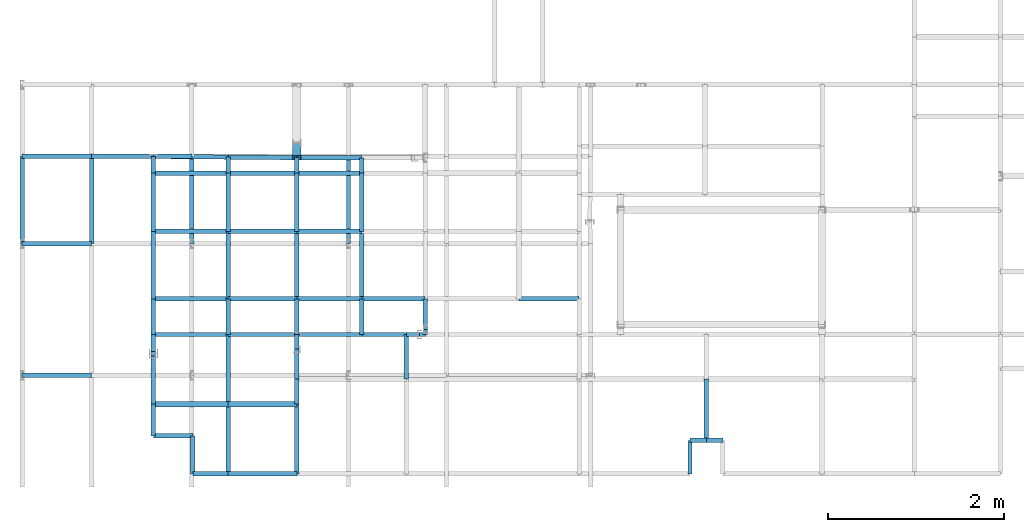
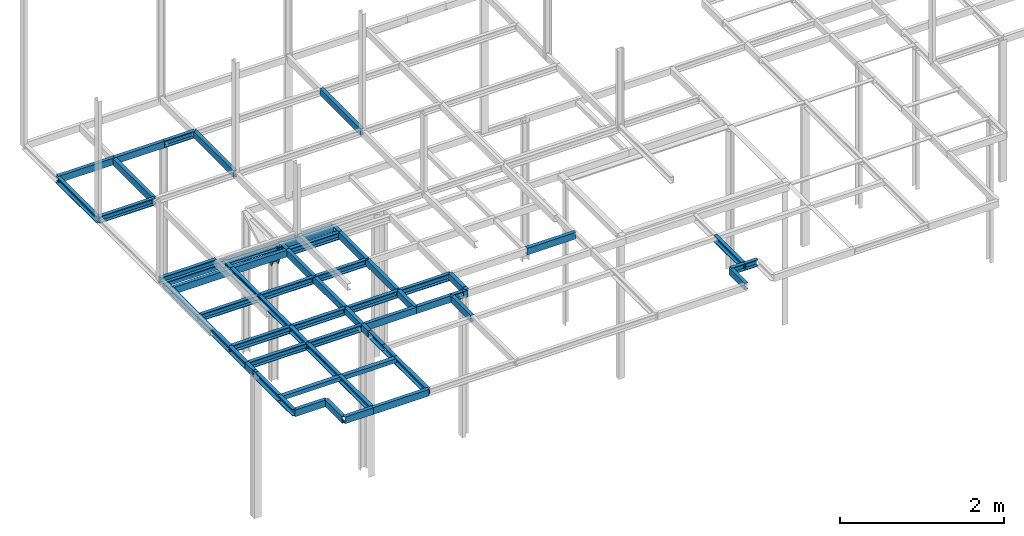
# Not in any storey, part 5 of 7: 68 beams, 1 member.
"""IFC2X3 model written with IfcOpenShell, lengths in centimetres."""

from ifc_helpers import new_model, si_unit, frame, frame_2d, origin_with_axes, origin_2d_with_axis, place, context, project, polyline, u_section, outline, extrude, material, element, save


model = new_model("IFC2X3")

# Units and contexts
model_context = context("Model", 3, precision=1e-05, world=origin_with_axes())
plan_context = context("Plan", 3, precision=1e-05, world=origin_with_axes())
ifc_project = project(units=[si_unit("LENGTHUNIT", "METRE", prefix="CENTI"), si_unit("AREAUNIT", "SQUARE_METRE", prefix="CENTI"), si_unit("VOLUMEUNIT", "CUBIC_METRE", prefix="CENTI"), si_unit("PLANEANGLEUNIT", "RADIAN"), si_unit("SOLIDANGLEUNIT", "STERADIAN"), si_unit("MASSUNIT", "GRAM"), si_unit("TIMEUNIT", "SECOND"), si_unit("THERMODYNAMICTEMPERATUREUNIT", "DEGREE_CELSIUS"), si_unit("LUMINOUSINTENSITYUNIT", "LUMEN")], contexts=[model_context, plan_context])

# Member
ifc_material = material()
member_placement = place(None, frame((-589.100036621094, 207.100006103516, 173.0), z_axis=(0.0, -0.377853352627, 0.925865456699), x_axis=(0.0, -0.925865471363, -0.377853363752)))
element("IfcMember", 1, at=member_placement, material=ifc_material, Name="UPN - de ala UPN 100", context=model_context, shape_type="SweptSolid", body=[
    extrude(u_section(Depth=10.0, FlangeWidth=5.0, WebThickness=0.6, FlangeThickness=0.85, FilletRadius=0.0, EdgeRadius=0.0, FlangeSlope=0.0, CentreOfGravityInX=0.0, at=origin_2d_with_axis()), origin_with_axes(), (0.0, 0.0, 1.0), 39.962609828766),
])

# Beams
beam_1_placement = place(None, frame((-667.0, 192.699996948242, 210.0), z_axis=(-0.999955816002, 0.009400321506, 0.0), x_axis=(0.009400321171, 0.999955832958, 0.0)))
element("IfcBeam", 2, at=beam_1_placement, material=ifc_material, Name="UPN - de ala UPN 100", context=model_context, shape_type="SweptSolid", body=[
    extrude(u_section(Depth=10.0, FlangeWidth=5.0, WebThickness=0.6, FlangeThickness=0.85, FilletRadius=0.0, EdgeRadius=0.0, FlangeSlope=0.0, CentreOfGravityInX=0.0, at=frame_2d((4.2114e-08, 0.0), x_axis=(1.0, 0.0))), origin_with_axes(), (0.0, 0.0, 1.0), 85.103796847111),
])
beam_2_placement = place(None, frame((-752.100036621094, 174.400009155273, 210.0), z_axis=(0.0, 1.0, 0.0), x_axis=(-1.0, 0.0, 0.0)))
element("IfcBeam", 3, at=beam_2_placement, material=ifc_material, Name="UPN - de ala UPN 100", context=model_context, shape_type="SweptSolid", body=[
    extrude(u_section(Depth=10.0, FlangeWidth=5.0, WebThickness=0.6, FlangeThickness=0.85, FilletRadius=0.0, EdgeRadius=0.0, FlangeSlope=0.0, CentreOfGravityInX=0.0, at=origin_2d_with_axis()), origin_with_axes(), (0.0, 0.0, 1.0), 19.099990844727),
])
beam_3_placement = place(None, frame((-589.100036621094, 192.0, 210.0), z_axis=(-0.999959629745, 0.008985481621, 0.0), x_axis=(-0.008985481225, -0.999959647655, 0.0)))
element("IfcBeam", 4, at=beam_3_placement, material=ifc_material, Name="UPN - de ala UPN 100", context=model_context, shape_type="SweptSolid", body=[
    extrude(u_section(Depth=10.0, FlangeWidth=5.0, WebThickness=0.6, FlangeThickness=0.85, FilletRadius=0.0, EdgeRadius=0.0, FlangeSlope=0.0, CentreOfGravityInX=0.0, at=frame_2d((-4.3358e-08, 0.0), x_axis=(1.0, 0.0))), origin_with_axes(), (0.0, 0.0, 1.0), 77.903108347244),
])
beam_4_placement = place(None, frame((-667.200012207031, 174.400009155273, 210.0), z_axis=(0.010928983338, 0.999940276878, 0.0), x_axis=(-0.999940276146, 0.0109289838, 0.0)))
element("IfcBeam", 5, at=beam_4_placement, material=ifc_material, Name="UPN - de ala UPN 100", context=model_context, shape_type="SweptSolid", body=[
    extrude(u_section(Depth=10.0, FlangeWidth=5.0, WebThickness=0.6, FlangeThickness=0.85, FilletRadius=0.0, EdgeRadius=0.0, FlangeSlope=0.0, CentreOfGravityInX=0.0, at=frame_2d((8.6e-09, 0.0), x_axis=(1.0, 0.0))), origin_with_axes(), (0.0, 0.0, 1.0), 18.301080790646),
])
beam_5_placement = place(None, frame((-515.200012207031, 191.900009155273, 210.0), z_axis=(-0.999999084621, 0.0013530544, 0.0), x_axis=(0.001353054424, 0.99999910593, 0.0)))
element("IfcBeam", 6, at=beam_5_placement, material=ifc_material, Name="UPN - de ala UPN 100", context=model_context, shape_type="SweptSolid", body=[
    extrude(u_section(Depth=10.0, FlangeWidth=5.0, WebThickness=0.6, FlangeThickness=0.85, FilletRadius=0.0, EdgeRadius=0.0, FlangeSlope=0.0, CentreOfGravityInX=0.0, at=frame_2d((3.74e-10, 0.0), x_axis=(1.0, 0.0))), origin_with_axes(), (0.0, 0.0, 1.0), 73.90009206062),
])
beam_6_placement = place(None, frame((-589.100036621094, 174.400009155273, 210.0), z_axis=(0.0, 1.0, 0.0), x_axis=(-1.0, 0.0, 0.0)))
element("IfcBeam", 7, at=beam_6_placement, material=ifc_material, Name="UPN - de ala UPN 100", context=model_context, shape_type="SweptSolid", body=[
    extrude(u_section(Depth=10.0, FlangeWidth=5.0, WebThickness=0.6, FlangeThickness=0.85, FilletRadius=0.0, EdgeRadius=0.0, FlangeSlope=0.0, CentreOfGravityInX=0.0, at=origin_2d_with_axis()), origin_with_axes(), (0.0, 0.0, 1.0), 17.599990844727),
])
beam_7_placement = place(None, frame((-515.200012207031, 174.400009155273, 210.0), z_axis=(0.0, 1.0, 0.0), x_axis=(-1.0, 0.0, 0.0)))
element("IfcBeam", 8, at=beam_7_placement, material=ifc_material, Name="UPN - de ala UPN 100", context=model_context, shape_type="SweptSolid", body=[
    extrude(u_section(Depth=10.0, FlangeWidth=5.0, WebThickness=0.6, FlangeThickness=0.85, FilletRadius=0.0, EdgeRadius=0.0, FlangeSlope=0.0, CentreOfGravityInX=0.0, at=origin_2d_with_axis()), origin_with_axes(), (0.0, 0.0, 1.0), 17.5),
])
beam_8_placement = place(None, frame((-667.200012207031, 174.400009155273, 210.0), z_axis=(-1.0, 0.0, 0.0), x_axis=(0.0, 1.0, 0.0)))
element("IfcBeam", 9, at=beam_8_placement, material=ifc_material, Name="UPN - de ala UPN 100", context=model_context, shape_type="SweptSolid", body=[
    extrude(u_section(Depth=10.0, FlangeWidth=5.0, WebThickness=0.6, FlangeThickness=0.85, FilletRadius=0.0, EdgeRadius=0.0, FlangeSlope=0.0, CentreOfGravityInX=0.0, at=origin_2d_with_axis()), origin_with_axes(), (0.0, 0.0, 1.0), 84.900024414062),
])
beam_9_placement = place(None, frame((-752.100036621094, 108.200004577637, 210.0), z_axis=(0.0, 1.0, 0.0), x_axis=(-1.0, 0.0, 0.0)))
element("IfcBeam", 10, at=beam_9_placement, material=ifc_material, Name="UPN - de ala UPN 100", context=model_context, shape_type="SweptSolid", body=[
    extrude(u_section(Depth=10.0, FlangeWidth=5.0, WebThickness=0.6, FlangeThickness=0.85, FilletRadius=0.0, EdgeRadius=0.0, FlangeSlope=0.0, CentreOfGravityInX=0.0, at=origin_2d_with_axis()), origin_with_axes(), (0.0, 0.0, 1.0), 66.200004577637),
])
beam_10_placement = place(None, frame((-589.100036621094, 174.400009155273, 210.0), z_axis=(-1.0, 0.0, 0.0), x_axis=(0.0, 1.0, 0.0)))
element("IfcBeam", 11, at=beam_10_placement, material=ifc_material, Name="UPN - de ala UPN 100", context=model_context, shape_type="SweptSolid", body=[
    extrude(u_section(Depth=10.0, FlangeWidth=5.0, WebThickness=0.6, FlangeThickness=0.85, FilletRadius=0.0, EdgeRadius=0.0, FlangeSlope=0.0, CentreOfGravityInX=0.0, at=origin_2d_with_axis()), origin_with_axes(), (0.0, 0.0, 1.0), 78.099975585938),
])
beam_11_placement = place(None, frame((-667.200012207031, 108.200004577637, 210.0), z_axis=(0.0, 1.0, 0.0), x_axis=(-1.0, 0.0, 0.0)))
element("IfcBeam", 12, at=beam_11_placement, material=ifc_material, Name="UPN - de ala UPN 100", context=model_context, shape_type="SweptSolid", body=[
    extrude(u_section(Depth=10.0, FlangeWidth=5.0, WebThickness=0.6, FlangeThickness=0.85, FilletRadius=0.0, EdgeRadius=0.0, FlangeSlope=0.0, CentreOfGravityInX=0.0, at=origin_2d_with_axis()), origin_with_axes(), (0.0, 0.0, 1.0), 66.200004577637),
])
beam_12_placement = place(None, frame((-515.200012207031, 174.400009155273, 210.0), z_axis=(-1.0, 0.0, 0.0), x_axis=(0.0, -1.0, 0.0)))
element("IfcBeam", 13, at=beam_12_placement, material=ifc_material, Name="UPN - de ala UPN 100", context=model_context, shape_type="SweptSolid", body=[
    extrude(u_section(Depth=10.0, FlangeWidth=5.0, WebThickness=0.6, FlangeThickness=0.85, FilletRadius=0.0, EdgeRadius=0.0, FlangeSlope=0.0, CentreOfGravityInX=0.0, at=origin_2d_with_axis()), origin_with_axes(), (0.0, 0.0, 1.0), 73.900024414062),
])
for number, where, z_axis, x_axis, name in (
    (14, (-589.100036621094, 108.200004577637, 210.0), (0.0, 1.0, 0.0), (1.0, 0.0, 0.0), "UPN - de ala UPN 100"),
    (15, (-515.200012207031, 108.200004577637, 210.0), (0.0, 1.0, 0.0), (1.0, 0.0, 0.0), "UPN - de ala UPN 100"),
):
    element("IfcBeam", number, at=place(None, frame(where, z_axis=z_axis, x_axis=x_axis)), material=ifc_material, Name=name, context=model_context, shape_type="SweptSolid", body=[
        extrude(u_section(Depth=10.0, FlangeWidth=5.0, WebThickness=0.6, FlangeThickness=0.85, FilletRadius=0.0, EdgeRadius=0.0, FlangeSlope=0.0, CentreOfGravityInX=0.0, at=origin_2d_with_axis()), origin_with_axes(), (0.0, 0.0, 1.0), 66.200004577637),
    ])
beam_13_placement = place(None, frame((-667.200012207031, 108.200004577637, 210.0), z_axis=(-1.0, 0.0, 0.0), x_axis=(0.0, -1.0, 0.0)))
element("IfcBeam", 16, at=beam_13_placement, material=ifc_material, Name="UPN - de ala UPN 100", context=model_context, shape_type="SweptSolid", body=[
    extrude(u_section(Depth=10.0, FlangeWidth=5.0, WebThickness=0.6, FlangeThickness=0.85, FilletRadius=0.0, EdgeRadius=0.0, FlangeSlope=0.0, CentreOfGravityInX=0.0, at=origin_2d_with_axis()), origin_with_axes(), (0.0, 0.0, 1.0), 84.900024414062),
])
beam_14_placement = place(None, frame((-752.100036621094, 31.599998474121, 210.0), z_axis=(0.0, 1.0, 0.0), x_axis=(-1.0, 0.0, 0.0)))
element("IfcBeam", 17, at=beam_14_placement, material=ifc_material, Name="UPN - de ala UPN 100", context=model_context, shape_type="SweptSolid", body=[
    extrude(u_section(Depth=10.0, FlangeWidth=5.0, WebThickness=0.6, FlangeThickness=0.85, FilletRadius=0.0, EdgeRadius=0.0, FlangeSlope=0.0, CentreOfGravityInX=0.0, at=origin_2d_with_axis()), origin_with_axes(), (0.0, 0.0, 1.0), 76.600006103516),
])
beam_15_placement = place(None, frame((-589.100036621094, 108.200004577637, 210.0), z_axis=(-1.0, 0.0, 0.0), x_axis=(0.0, -1.0, 0.0)))
element("IfcBeam", 18, at=beam_15_placement, material=ifc_material, Name="UPN - de ala UPN 100", context=model_context, shape_type="SweptSolid", body=[
    extrude(u_section(Depth=10.0, FlangeWidth=5.0, WebThickness=0.6, FlangeThickness=0.85, FilletRadius=0.0, EdgeRadius=0.0, FlangeSlope=0.0, CentreOfGravityInX=0.0, at=origin_2d_with_axis()), origin_with_axes(), (0.0, 0.0, 1.0), 78.099975585938),
])
beam_16_placement = place(None, frame((-667.200012207031, 31.599998474121, 210.0), z_axis=(0.0, 1.0, 0.0), x_axis=(-1.0, 0.0, 0.0)))
element("IfcBeam", 19, at=beam_16_placement, material=ifc_material, Name="UPN - de ala UPN 100", context=model_context, shape_type="SweptSolid", body=[
    extrude(u_section(Depth=10.0, FlangeWidth=5.0, WebThickness=0.6, FlangeThickness=0.85, FilletRadius=0.0, EdgeRadius=0.0, FlangeSlope=0.0, CentreOfGravityInX=0.0, at=origin_2d_with_axis()), origin_with_axes(), (0.0, 0.0, 1.0), 76.600006103516),
])
beam_17_placement = place(None, frame((-515.200012207031, 108.200004577637, 210.0), z_axis=(-1.0, 0.0, 0.0), x_axis=(0.0, -1.0, 0.0)))
element("IfcBeam", 20, at=beam_17_placement, material=ifc_material, Name="UPN - de ala UPN 100", context=model_context, shape_type="SweptSolid", body=[
    extrude(u_section(Depth=10.0, FlangeWidth=5.0, WebThickness=0.6, FlangeThickness=0.85, FilletRadius=0.0, EdgeRadius=0.0, FlangeSlope=0.0, CentreOfGravityInX=0.0, at=origin_2d_with_axis()), origin_with_axes(), (0.0, 0.0, 1.0), 73.900024414062),
])
for number, where, z_axis, x_axis, name in (
    (21, (-589.100036621094, 31.599998474121, 210.0), (0.0, 1.0, 0.0), (1.0, 0.0, 0.0), "UPN - de ala UPN 100"),
    (22, (-515.200012207031, 31.599998474121, 210.0), (0.0, 1.0, 0.0), (1.0, 0.0, 0.0), "UPN - de ala UPN 100"),
):
    element("IfcBeam", number, at=place(None, frame(where, z_axis=z_axis, x_axis=x_axis)), material=ifc_material, Name=name, context=model_context, shape_type="SweptSolid", body=[
        extrude(u_section(Depth=10.0, FlangeWidth=5.0, WebThickness=0.6, FlangeThickness=0.85, FilletRadius=0.0, EdgeRadius=0.0, FlangeSlope=0.0, CentreOfGravityInX=0.0, at=origin_2d_with_axis()), origin_with_axes(), (0.0, 0.0, 1.0), 76.600006103516),
    ])
beam_18_placement = place(None, frame((-667.200012207031, 31.60000038147, 210.0), z_axis=(-1.0, 0.0, 0.0), x_axis=(0.0, -1.0, 0.0)))
element("IfcBeam", 23, at=beam_18_placement, material=ifc_material, Name="UPN - de ala UPN 100", context=model_context, shape_type="SweptSolid", body=[
    extrude(u_section(Depth=10.0, FlangeWidth=5.0, WebThickness=0.6, FlangeThickness=0.85, FilletRadius=0.0, EdgeRadius=0.0, FlangeSlope=0.0, CentreOfGravityInX=0.0, at=frame_2d((9.53674e-07, 0.0), x_axis=(1.0, 0.0))), origin_with_axes(), (0.0, 0.0, 1.0), 84.900024414062),
])
beam_19_placement = place(None, frame((-752.100036621094, -8.999998092651, 210.0), z_axis=(0.0, 1.0, 0.0), x_axis=(-1.0, 0.0, 0.0)))
element("IfcBeam", 24, at=beam_19_placement, material=ifc_material, Name="UPN - de ala UPN 100", context=model_context, shape_type="SweptSolid", body=[
    extrude(u_section(Depth=10.0, FlangeWidth=5.0, WebThickness=0.6, FlangeThickness=0.85, FilletRadius=0.0, EdgeRadius=0.0, FlangeSlope=0.0, CentreOfGravityInX=0.0, at=origin_2d_with_axis()), origin_with_axes(), (0.0, 0.0, 1.0), 40.599998474121),
])
beam_20_placement = place(None, frame((-589.100036621094, 31.60000038147, 210.0), z_axis=(-1.0, 0.0, 0.0), x_axis=(0.0, -1.0, 0.0)))
element("IfcBeam", 25, at=beam_20_placement, material=ifc_material, Name="UPN - de ala UPN 100", context=model_context, shape_type="SweptSolid", body=[
    extrude(u_section(Depth=10.0, FlangeWidth=5.0, WebThickness=0.6, FlangeThickness=0.85, FilletRadius=0.0, EdgeRadius=0.0, FlangeSlope=0.0, CentreOfGravityInX=0.0, at=frame_2d((9.53674e-07, 0.0), x_axis=(1.0, 0.0))), origin_with_axes(), (0.0, 0.0, 1.0), 78.099975585938),
])
beam_21_placement = place(None, frame((-667.200012207031, -8.999998092651, 210.0), z_axis=(0.0, 1.0, 0.0), x_axis=(-1.0, 0.0, 0.0)))
element("IfcBeam", 26, at=beam_21_placement, material=ifc_material, Name="UPN - de ala UPN 100", context=model_context, shape_type="SweptSolid", body=[
    extrude(u_section(Depth=10.0, FlangeWidth=5.0, WebThickness=0.6, FlangeThickness=0.85, FilletRadius=0.0, EdgeRadius=0.0, FlangeSlope=0.0, CentreOfGravityInX=0.0, at=origin_2d_with_axis()), origin_with_axes(), (0.0, 0.0, 1.0), 40.599998474121),
])
beam_22_placement = place(None, frame((-515.200012207031, 31.60000038147, 210.0), z_axis=(-1.0, 0.0, 0.0), x_axis=(0.0, -1.0, 0.0)))
element("IfcBeam", 27, at=beam_22_placement, material=ifc_material, Name="UPN - de ala UPN 100", context=model_context, shape_type="SweptSolid", body=[
    extrude(u_section(Depth=10.0, FlangeWidth=5.0, WebThickness=0.6, FlangeThickness=0.85, FilletRadius=0.0, EdgeRadius=0.0, FlangeSlope=0.0, CentreOfGravityInX=0.0, at=frame_2d((9.53674e-07, 0.0), x_axis=(1.0, 0.0))), origin_with_axes(), (0.0, 0.0, 1.0), 73.900024414062),
])
beam_23_placement = place(None, frame((-589.100036621094, -8.999998092651, 210.0), z_axis=(0.0, 1.0, 0.0), x_axis=(1.0, 0.0, 0.0)))
element("IfcBeam", 28, at=beam_23_placement, material=ifc_material, Name="UPN - de ala UPN 100", context=model_context, shape_type="SweptSolid", body=[
    extrude(u_section(Depth=10.0, FlangeWidth=5.0, WebThickness=0.6, FlangeThickness=0.85, FilletRadius=0.0, EdgeRadius=0.0, FlangeSlope=0.0, CentreOfGravityInX=0.0, at=origin_2d_with_axis()), origin_with_axes(), (0.0, 0.0, 1.0), 40.599998474121),
])
beam_24_placement = place(None, frame((-443.100006103516, 31.60000038147, 210.0), z_axis=(-1.0, 0.0, 0.0), x_axis=(0.0, -1.0, 0.0)))
element("IfcBeam", 29, at=beam_24_placement, material=ifc_material, Name="UPN - de ala UPN 100", context=model_context, shape_type="SweptSolid", body=[
    extrude(u_section(Depth=10.0, FlangeWidth=5.0, WebThickness=0.6, FlangeThickness=0.85, FilletRadius=0.0, EdgeRadius=0.0, FlangeSlope=0.0, CentreOfGravityInX=0.0, at=frame_2d((9.53674e-07, 0.0), x_axis=(1.0, 0.0))), origin_with_axes(), (0.0, 0.0, 1.0), 72.100006103516),
])
beam_25_placement = place(None, frame((-515.200012207031, -8.999998092651, 210.0), z_axis=(0.0, 1.0, 0.0), x_axis=(1.0, 0.0, 0.0)))
element("IfcBeam", 30, at=beam_25_placement, material=ifc_material, Name="UPN - de ala UPN 100", context=model_context, shape_type="SweptSolid", body=[
    extrude(u_section(Depth=10.0, FlangeWidth=5.0, WebThickness=0.6, FlangeThickness=0.85, FilletRadius=0.0, EdgeRadius=0.0, FlangeSlope=0.0, CentreOfGravityInX=0.0, at=origin_2d_with_axis()), origin_with_axes(), (0.0, 0.0, 1.0), 40.599998474121),
])
beam_26_placement = place(None, frame((-443.0, -3.10000038147, 210.0), z_axis=(-0.002882008242, 0.999995847006, 0.0), x_axis=(0.999995827675, 0.002882008208, 0.0)))
element("IfcBeam", 31, at=beam_26_placement, material=ifc_material, Name="UPN - de ala UPN 100", context=model_context, shape_type="SweptSolid", body=[
    extrude(u_section(Depth=10.0, FlangeWidth=5.0, WebThickness=0.6, FlangeThickness=0.85, FilletRadius=0.0, EdgeRadius=0.0, FlangeSlope=0.0, CentreOfGravityInX=0.0, at=frame_2d((7.57e-10, 0.0), x_axis=(1.0, 0.0))), origin_with_axes(), (0.0, 0.0, 1.0), 34.700144872446),
])
beam_27_placement = place(None, frame((-268.0, 31.60000038147, 210.0), z_axis=(-1.0, 0.0, 0.0), x_axis=(0.0, 1.0, 0.0)))
element("IfcBeam", 32, at=beam_27_placement, material=ifc_material, Name="UPN - de ala UPN 100", context=model_context, shape_type="SweptSolid", body=[
    extrude(u_section(Depth=10.0, FlangeWidth=5.0, WebThickness=0.6, FlangeThickness=0.85, FilletRadius=0.0, EdgeRadius=0.0, FlangeSlope=0.0, CentreOfGravityInX=0.0, at=frame_2d((9.53674e-07, 0.0), x_axis=(1.0, 0.0))), origin_with_axes(), (0.0, 0.0, 1.0), 68.600006103516),
])
beam_28_placement = place(None, frame((-443.0, -8.999999761581, 210.0), z_axis=(0.0, 1.0, 0.0), x_axis=(1.0, 0.0, 0.0)))
element("IfcBeam", 33, at=beam_28_placement, material=ifc_material, Name="UPN - de ala UPN 100", context=model_context, shape_type="SweptSolid", body=[
    extrude(u_section(Depth=10.0, FlangeWidth=5.0, WebThickness=0.6, FlangeThickness=0.85, FilletRadius=0.0, EdgeRadius=0.0, FlangeSlope=0.0, CentreOfGravityInX=0.0, at=origin_2d_with_axis()), origin_with_axes(), (0.0, 0.0, 1.0), 5.89999961853),
])
beam_29_placement = place(None, frame((-667.200012207031, -9.0, 210.0), z_axis=(-1.0, 0.0, 0.0), x_axis=(0.0, -1.0, 0.0)))
element("IfcBeam", 34, at=beam_29_placement, material=ifc_material, Name="UPN - de ala UPN 100", context=model_context, shape_type="SweptSolid", body=[
    extrude(u_section(Depth=10.0, FlangeWidth=5.0, WebThickness=0.6, FlangeThickness=0.85, FilletRadius=0.0, EdgeRadius=0.0, FlangeSlope=0.0, CentreOfGravityInX=0.0, at=origin_2d_with_axis()), origin_with_axes(), (0.0, 0.0, 1.0), 84.900024414062),
])
beam_30_placement = place(None, frame((-752.100036621094, -28.200000762939, 210.0), z_axis=(0.0, 1.0, 0.0), x_axis=(1.0, 0.0, 0.0)))
element("IfcBeam", 35, at=beam_30_placement, material=ifc_material, Name="UPN - de ala UPN 100", context=model_context, shape_type="SweptSolid", body=[
    extrude(u_section(Depth=10.0, FlangeWidth=5.0, WebThickness=0.6, FlangeThickness=0.85, FilletRadius=0.0, EdgeRadius=0.0, FlangeSlope=0.0, CentreOfGravityInX=0.0, at=origin_2d_with_axis()), origin_with_axes(), (0.0, 0.0, 1.0), 19.200000762939),
])
beam_31_placement = place(None, frame((-589.100036621094, -9.0, 210.0), z_axis=(-1.0, 0.0, 0.0), x_axis=(0.0, -1.0, 0.0)))
element("IfcBeam", 36, at=beam_31_placement, material=ifc_material, Name="UPN - de ala UPN 100", context=model_context, shape_type="SweptSolid", body=[
    extrude(u_section(Depth=10.0, FlangeWidth=5.0, WebThickness=0.6, FlangeThickness=0.85, FilletRadius=0.0, EdgeRadius=0.0, FlangeSlope=0.0, CentreOfGravityInX=0.0, at=origin_2d_with_axis()), origin_with_axes(), (0.0, 0.0, 1.0), 78.099975585938),
])
beam_32_placement = place(None, frame((-667.200012207031, -88.200004577637, 210.0), z_axis=(0.0, 1.0, 0.0), x_axis=(-1.0, 0.0, 0.0)))
element("IfcBeam", 37, at=beam_32_placement, material=ifc_material, Name="UPN - de ala UPN 100", context=model_context, shape_type="SweptSolid", body=[
    extrude(u_section(Depth=10.0, FlangeWidth=5.0, WebThickness=0.6, FlangeThickness=0.85, FilletRadius=0.0, EdgeRadius=0.0, FlangeSlope=0.0, CentreOfGravityInX=0.0, at=origin_2d_with_axis()), origin_with_axes(), (0.0, 0.0, 1.0), 79.200004577637),
])
beam_33_placement = place(None, frame((-515.200012207031, -9.0, 210.0), z_axis=(-1.0, 0.0, 0.0), x_axis=(0.0, 1.0, 0.0)))
element("IfcBeam", 38, at=beam_33_placement, material=ifc_material, Name="UPN - de ala UPN 100", context=model_context, shape_type="SweptSolid", body=[
    extrude(u_section(Depth=10.0, FlangeWidth=5.0, WebThickness=0.6, FlangeThickness=0.85, FilletRadius=0.0, EdgeRadius=0.0, FlangeSlope=0.0, CentreOfGravityInX=0.0, at=frame_2d((2.38419e-07, 0.0), x_axis=(1.0, 0.0))), origin_with_axes(), (0.0, 0.0, 1.0), 73.900024414062),
])
beam_34_placement = place(None, frame((-589.100036621094, -25.700000762939, 210.0), z_axis=(0.0, 1.0, 0.0), x_axis=(1.0, 0.0, 0.0)))
element("IfcBeam", 39, at=beam_34_placement, material=ifc_material, Name="UPN - de ala UPN 100", context=model_context, shape_type="SweptSolid", body=[
    extrude(u_section(Depth=10.0, FlangeWidth=5.0, WebThickness=0.6, FlangeThickness=0.85, FilletRadius=0.0, EdgeRadius=0.0, FlangeSlope=0.0, CentreOfGravityInX=0.0, at=origin_2d_with_axis()), origin_with_axes(), (0.0, 0.0, 1.0), 16.700000762939),
])
beam_35_placement = place(None, frame((-464.600006103516, -9.0, 210.0), z_axis=(-1.0, 0.0, 0.0), x_axis=(0.0, 1.0, 0.0)))
element("IfcBeam", 40, at=beam_35_placement, material=ifc_material, Name="UPN - de ala UPN 100", context=model_context, shape_type="SweptSolid", body=[
    extrude(u_section(Depth=10.0, FlangeWidth=5.0, WebThickness=0.6, FlangeThickness=0.85, FilletRadius=0.0, EdgeRadius=0.0, FlangeSlope=0.0, CentreOfGravityInX=0.0, at=frame_2d((2.38419e-07, 0.0), x_axis=(1.0, 0.0))), origin_with_axes(), (0.0, 0.0, 1.0), 50.600006103516),
])
beam_36_placement = place(None, frame((-449.600006103516, -9.0, 210.0), z_axis=(-1.0, 0.0, 0.0), x_axis=(0.0, -1.0, 0.0)))
element("IfcBeam", 41, at=beam_36_placement, material=ifc_material, Name="UPN - de ala UPN 100", context=model_context, shape_type="SweptSolid", body=[
    extrude(u_section(Depth=10.0, FlangeWidth=5.0, WebThickness=0.6, FlangeThickness=0.85, FilletRadius=0.0, EdgeRadius=0.0, FlangeSlope=0.0, CentreOfGravityInX=0.0, at=origin_2d_with_axis()), origin_with_axes(), (0.0, 0.0, 1.0), 15.0),
])
beam_37_placement = place(None, frame((-464.600006103516, -59.600002288818, 210.0), z_axis=(0.0, 1.0, 0.0), x_axis=(1.0, 0.0, 0.0)))
element("IfcBeam", 42, at=beam_37_placement, material=ifc_material, Name="UPN - de ala UPN 100", context=model_context, shape_type="SweptSolid", body=[
    extrude(u_section(Depth=10.0, FlangeWidth=5.0, WebThickness=0.6, FlangeThickness=0.85, FilletRadius=0.0, EdgeRadius=0.0, FlangeSlope=0.0, CentreOfGravityInX=0.0, at=origin_2d_with_axis()), origin_with_axes(), (0.0, 0.0, 1.0), 50.600002288818),
])
beam_38_placement = place(None, frame((-443.0, -9.0, 210.0), z_axis=(-1.0, 0.0, 0.0), x_axis=(0.0, 1.0, 0.0)))
element("IfcBeam", 43, at=beam_38_placement, material=ifc_material, Name="UPN - de ala UPN 100", context=model_context, shape_type="SweptSolid", body=[
    extrude(u_section(Depth=10.0, FlangeWidth=5.0, WebThickness=0.6, FlangeThickness=0.85, FilletRadius=0.0, EdgeRadius=0.0, FlangeSlope=0.0, CentreOfGravityInX=0.0, at=frame_2d((2.38419e-07, 0.0), x_axis=(1.0, 0.0))), origin_with_axes(), (0.0, 0.0, 1.0), 6.600006103516),
])
beam_39_placement = place(None, frame((-589.100036621094, -59.600002288818, 210.0), z_axis=(0.0, 1.0, 0.0), x_axis=(-1.0, 0.0, 0.0)))
element("IfcBeam", 44, at=beam_39_placement, material=ifc_material, Name="UPN - de ala UPN 100", context=model_context, shape_type="SweptSolid", body=[
    extrude(u_section(Depth=10.0, FlangeWidth=5.0, WebThickness=0.6, FlangeThickness=0.85, FilletRadius=0.0, EdgeRadius=0.0, FlangeSlope=0.0, CentreOfGravityInX=0.0, at=origin_2d_with_axis()), origin_with_axes(), (0.0, 0.0, 1.0), 33.900001525879),
])
beam_40_placement = place(None, frame((-752.100036621094, -33.200000762939, 210.0), z_axis=(0.0, 1.0, 0.0), x_axis=(-1.0, 0.0, 0.0)))
element("IfcBeam", 45, at=beam_40_placement, material=ifc_material, Name="UPN - de ala UPN 100", context=model_context, shape_type="SweptSolid", body=[
    extrude(u_section(Depth=10.0, FlangeWidth=5.0, WebThickness=0.6, FlangeThickness=0.85, FilletRadius=0.0, EdgeRadius=0.0, FlangeSlope=0.0, CentreOfGravityInX=0.0, at=origin_2d_with_axis()), origin_with_axes(), (0.0, 0.0, 1.0), 5.0),
])
beam_41_placement = place(None, frame((-752.100036621094, -88.200004577637, 210.0), z_axis=(0.0, 1.0, 0.0), x_axis=(-1.0, 0.0, 0.0)))
element("IfcBeam", 46, at=beam_41_placement, material=ifc_material, Name="UPN - de ala UPN 100", context=model_context, shape_type="SweptSolid", body=[
    extrude(u_section(Depth=10.0, FlangeWidth=5.0, WebThickness=0.6, FlangeThickness=0.85, FilletRadius=0.0, EdgeRadius=0.0, FlangeSlope=0.0, CentreOfGravityInX=0.0, at=origin_2d_with_axis()), origin_with_axes(), (0.0, 0.0, 1.0), 55.000003814697),
])
beam_42_placement = place(None, frame((-589.100036621094, -88.200004577637, 210.0), z_axis=(0.0, 1.0, 0.0), x_axis=(-1.0, 0.0, 0.0)))
element("IfcBeam", 47, at=beam_42_placement, material=ifc_material, Name="UPN - de ala UPN 100", context=model_context, shape_type="SweptSolid", body=[
    extrude(u_section(Depth=10.0, FlangeWidth=5.0, WebThickness=0.6, FlangeThickness=0.85, FilletRadius=0.0, EdgeRadius=0.0, FlangeSlope=0.0, CentreOfGravityInX=0.0, at=origin_2d_with_axis()), origin_with_axes(), (0.0, 0.0, 1.0), 28.600002288818),
])
beam_43_placement = place(None, frame((-123.300003051758, -129.299999237061, 210.0), z_axis=(0.0, 1.0, 0.0), x_axis=(-1.0, 0.0, 0.0)))
element("IfcBeam", 48, at=beam_43_placement, material=ifc_material, Name="UPN - de ala UPN 100", context=model_context, shape_type="SweptSolid", body=[
    extrude(u_section(Depth=10.0, FlangeWidth=5.0, WebThickness=0.6, FlangeThickness=0.85, FilletRadius=0.0, EdgeRadius=0.0, FlangeSlope=0.0, CentreOfGravityInX=0.0, at=origin_2d_with_axis()), origin_with_axes(), (0.0, 0.0, 1.0), 69.699996948242),
])
beam_44_placement = place(None, frame((-667.200012207031, -88.200004577637, 210.0), z_axis=(-1.0, 0.0, 0.0), x_axis=(0.0, 0.0, -1.0)))
element("IfcBeam", 49, at=beam_44_placement, material=ifc_material, context=model_context, shape_type="SweptSolid", body=[
    extrude(outline(polyline([(-3.0, -3.0), (-2.5, -3.0), (-2.5, 2.5), (3.0, 2.5), (3.0, 3.0), (-3.0, 3.0), (-3.0, -3.0)])), origin_with_axes(), (0.0, 0.0, 1.0), 84.900024414062),
])
beam_45_placement = place(None, frame((-752.100036621094, -124.200004577637, 210.0), z_axis=(0.0, 1.0, 0.0), x_axis=(-1.0, 0.0, 0.0)))
element("IfcBeam", 50, at=beam_45_placement, material=ifc_material, Name="UPN - de ala UPN 100", context=model_context, shape_type="SweptSolid", body=[
    extrude(u_section(Depth=10.0, FlangeWidth=5.0, WebThickness=0.6, FlangeThickness=0.85, FilletRadius=0.0, EdgeRadius=0.0, FlangeSlope=0.0, CentreOfGravityInX=0.0, at=origin_2d_with_axis()), origin_with_axes(), (0.0, 0.0, 1.0), 36.0),
])
beam_46_placement = place(None, frame((-589.100036621094, -88.200004577637, 210.0), z_axis=(-1.0, 0.0, 0.0), x_axis=(0.0, 0.0, -1.0)))
element("IfcBeam", 51, at=beam_46_placement, material=ifc_material, context=model_context, shape_type="SweptSolid", body=[
    extrude(outline(polyline([(-3.0, -3.0), (-2.5, -3.0), (-2.5, 2.5), (3.0, 2.5), (3.0, 3.0), (-3.0, 3.0), (-3.0, -3.0)])), origin_with_axes(), (0.0, 0.0, 1.0), 78.099975585938),
])
for number, where, z_axis, x_axis, name in (
    (52, (-667.200012207031, -167.5, 210.0), (0.0, 1.0, 0.0), (-1.0, 0.0, 0.0), "UPN - de ala UPN 100"),
    (53, (-589.100036621094, -167.5, 210.0), (0.0, 1.0, 0.0), (-1.0, 0.0, 0.0), "UPN - de ala UPN 100"),
):
    element("IfcBeam", number, at=place(None, frame(where, z_axis=z_axis, x_axis=x_axis)), material=ifc_material, Name=name, context=model_context, shape_type="SweptSolid", body=[
        extrude(u_section(Depth=10.0, FlangeWidth=5.0, WebThickness=0.6, FlangeThickness=0.85, FilletRadius=0.0, EdgeRadius=0.0, FlangeSlope=0.0, CentreOfGravityInX=0.0, at=origin_2d_with_axis()), origin_with_axes(), (0.0, 0.0, 1.0), 79.299995422363),
    ])
beam_47_placement = place(None, frame((-707.200012207031, -124.200004577637, 210.0), z_axis=(-1.0, 0.0, 0.0), x_axis=(0.0, 1.0, 0.0)))
element("IfcBeam", 54, at=beam_47_placement, material=ifc_material, Name="UPN - de ala UPN 100", context=model_context, shape_type="SweptSolid", body=[
    extrude(u_section(Depth=10.0, FlangeWidth=5.0, WebThickness=0.6, FlangeThickness=0.85, FilletRadius=0.0, EdgeRadius=0.0, FlangeSlope=0.0, CentreOfGravityInX=0.0, at=origin_2d_with_axis()), origin_with_axes(), (0.0, 0.0, 1.0), 44.900024414062),
])
beam_48_placement = place(None, frame((-707.200012207031, -167.5, 210.0), z_axis=(0.0, 1.0, 0.0), x_axis=(1.0, 0.0, 0.0)))
element("IfcBeam", 55, at=beam_48_placement, material=ifc_material, Name="UPN - de ala UPN 100", context=model_context, shape_type="SweptSolid", body=[
    extrude(u_section(Depth=10.0, FlangeWidth=5.0, WebThickness=0.6, FlangeThickness=0.85, FilletRadius=0.0, EdgeRadius=0.0, FlangeSlope=0.0, CentreOfGravityInX=0.0, at=origin_2d_with_axis()), origin_with_axes(), (0.0, 0.0, 1.0), 43.299995422363),
])
beam_49_placement = place(None, frame((-123.300003051758, -129.300003051758, 210.0), z_axis=(-1.0, 0.0, 0.0), x_axis=(0.0, -1.0, 0.0)))
element("IfcBeam", 56, at=beam_49_placement, material=ifc_material, Name="UPN - de ala UPN 100", context=model_context, shape_type="SweptSolid", body=[
    extrude(u_section(Depth=10.0, FlangeWidth=5.0, WebThickness=0.6, FlangeThickness=0.85, FilletRadius=0.0, EdgeRadius=0.0, FlangeSlope=0.0, CentreOfGravityInX=0.0, at=origin_2d_with_axis()), origin_with_axes(), (0.0, 0.0, 1.0), 18.699996948242),
])
beam_50_placement = place(None, frame((-142.0, -167.5, 210.0), z_axis=(0.0, 1.0, 0.0), x_axis=(1.0, 0.0, 0.0)))
element("IfcBeam", 57, at=beam_50_placement, material=ifc_material, Name="UPN - de ala UPN 100", context=model_context, shape_type="SweptSolid", body=[
    extrude(u_section(Depth=10.0, FlangeWidth=5.0, WebThickness=0.6, FlangeThickness=0.85, FilletRadius=0.0, EdgeRadius=0.0, FlangeSlope=0.0, CentreOfGravityInX=0.0, at=origin_2d_with_axis()), origin_with_axes(), (0.0, 0.0, 1.0), 38.199996948242),
])
beam_51_placement = place(None, frame((-104.599998474121, -129.300003051758, 210.0), z_axis=(-1.0, 0.0, 0.0), x_axis=(0.0, -1.0, 0.0)))
element("IfcBeam", 58, at=beam_51_placement, material=ifc_material, Name="UPN - de ala UPN 100", context=model_context, shape_type="SweptSolid", body=[
    extrude(u_section(Depth=10.0, FlangeWidth=5.0, WebThickness=0.6, FlangeThickness=0.85, FilletRadius=0.0, EdgeRadius=0.0, FlangeSlope=0.0, CentreOfGravityInX=0.0, at=origin_2d_with_axis()), origin_with_axes(), (0.0, 0.0, 1.0), 18.700004577637),
])
beam_52_placement = place(None, frame((-667.200012207031, -167.5, 210.0), z_axis=(-1.0, 0.0, 0.0), x_axis=(0.0, 1.0, 0.0)))
element("IfcBeam", 59, at=beam_52_placement, material=ifc_material, Name="UPN - de ala UPN 100", context=model_context, shape_type="SweptSolid", body=[
    extrude(u_section(Depth=10.0, FlangeWidth=5.0, WebThickness=0.6, FlangeThickness=0.85, FilletRadius=0.0, EdgeRadius=0.0, FlangeSlope=0.0, CentreOfGravityInX=0.0, at=origin_2d_with_axis()), origin_with_axes(), (0.0, 0.0, 1.0), 40.0),
])
beam_53_placement = place(None, frame((-589.100036621094, -167.5, 210.0), z_axis=(-1.0, 0.0, 0.0), x_axis=(0.0, 1.0, 0.0)))
element("IfcBeam", 60, at=beam_53_placement, material=ifc_material, Name="UPN - de ala UPN 100", context=model_context, shape_type="SweptSolid", body=[
    extrude(u_section(Depth=10.0, FlangeWidth=5.0, WebThickness=0.6, FlangeThickness=0.85, FilletRadius=0.0, EdgeRadius=0.0, FlangeSlope=0.0, CentreOfGravityInX=0.0, at=origin_2d_with_axis()), origin_with_axes(), (0.0, 0.0, 1.0), 78.099975585938),
])
beam_54_placement = place(None, frame((-822.400024414062, 193.5, 416.5), z_axis=(-1.0, 0.0, 0.0), x_axis=(0.0, 1.0, 0.0)))
element("IfcBeam", 61, at=beam_54_placement, material=ifc_material, Name="UPN - de ala UPN 100", context=model_context, shape_type="SweptSolid", body=[
    extrude(u_section(Depth=10.0, FlangeWidth=5.0, WebThickness=0.6, FlangeThickness=0.85, FilletRadius=0.0, EdgeRadius=0.0, FlangeSlope=0.0, CentreOfGravityInX=0.0, at=origin_2d_with_axis()), origin_with_axes(), (0.0, 0.0, 1.0), 78.899963378906),
])
beam_55_placement = place(None, frame((-901.299987792969, 94.200004577637, 416.5), z_axis=(0.0, 1.0, 0.0), x_axis=(-1.0, 0.0, 0.0)))
element("IfcBeam", 62, at=beam_55_placement, material=ifc_material, Name="UPN - de ala UPN 100", context=model_context, shape_type="SweptSolid", body=[
    extrude(u_section(Depth=10.0, FlangeWidth=5.0, WebThickness=0.6, FlangeThickness=0.85, FilletRadius=0.0, EdgeRadius=0.0, FlangeSlope=0.0, CentreOfGravityInX=0.0, at=origin_2d_with_axis()), origin_with_axes(), (0.0, 0.0, 1.0), 99.299995422363),
])
beam_56_placement = place(None, frame((-752.100036621094, 193.5, 416.5), z_axis=(-1.0, 0.0, 0.0), x_axis=(0.0, 1.0, 0.0)))
element("IfcBeam", 63, at=beam_56_placement, material=ifc_material, Name="UPN - de ala UPN 100", context=model_context, shape_type="SweptSolid", body=[
    extrude(u_section(Depth=10.0, FlangeWidth=5.0, WebThickness=0.6, FlangeThickness=0.85, FilletRadius=0.0, EdgeRadius=0.0, FlangeSlope=0.0, CentreOfGravityInX=0.0, at=origin_2d_with_axis()), origin_with_axes(), (0.0, 0.0, 1.0), 70.299987792969),
])
beam_57_placement = place(None, frame((-822.400024414062, 94.200004577637, 416.5), z_axis=(0.0, 1.0, 0.0), x_axis=(1.0, 0.0, 0.0)))
element("IfcBeam", 64, at=beam_57_placement, material=ifc_material, Name="UPN - de ala UPN 100", context=model_context, shape_type="SweptSolid", body=[
    extrude(u_section(Depth=10.0, FlangeWidth=5.0, WebThickness=0.6, FlangeThickness=0.85, FilletRadius=0.0, EdgeRadius=0.0, FlangeSlope=0.0, CentreOfGravityInX=0.0, at=origin_2d_with_axis()), origin_with_axes(), (0.0, 0.0, 1.0), 99.299995422363),
])
beam_58_placement = place(None, frame((-708.5, 193.5, 416.5), z_axis=(-1.0, 0.0, 0.0), x_axis=(0.0, -1.0, 0.0)))
element("IfcBeam", 65, at=beam_58_placement, material=ifc_material, Name="UPN - de ala UPN 100", context=model_context, shape_type="SweptSolid", body=[
    extrude(u_section(Depth=10.0, FlangeWidth=5.0, WebThickness=0.6, FlangeThickness=0.85, FilletRadius=0.0, EdgeRadius=0.0, FlangeSlope=0.0, CentreOfGravityInX=0.0, at=origin_2d_with_axis()), origin_with_axes(), (0.0, 0.0, 1.0), 43.600036621094),
])
for number, where, z_axis, x_axis, name in (
    (66, (-708.5, 94.200004577637, 416.5), (0.0, 1.0, 0.0), (1.0, 0.0, 0.0), "UPN - de ala UPN 100"),
    (67, (-530.299987792969, 94.200004577637, 416.5), (0.0, 1.0, 0.0), (1.0, 0.0, 0.0), "UPN - de ala UPN 100"),
):
    element("IfcBeam", number, at=place(None, frame(where, z_axis=z_axis, x_axis=x_axis)), material=ifc_material, Name=name, context=model_context, shape_type="SweptSolid", body=[
        extrude(u_section(Depth=10.0, FlangeWidth=5.0, WebThickness=0.6, FlangeThickness=0.85, FilletRadius=0.0, EdgeRadius=0.0, FlangeSlope=0.0, CentreOfGravityInX=0.0, at=origin_2d_with_axis()), origin_with_axes(), (0.0, 0.0, 1.0), 99.299995422363),
    ])
for number, where, z_axis, x_axis, name in (
    (68, (-822.400024414062, 94.200004577637, 416.5), (-1.0, 0.0, 0.0), (0.0, -1.0, 0.0), "UPN - de ala UPN 100"),
    (69, (-822.400024414062, -55.5, 416.5), (-1.0, 0.0, 0.0), (0.0, -1.0, 0.0), "UPN - de ala UPN 100"),
):
    element("IfcBeam", number, at=place(None, frame(where, z_axis=z_axis, x_axis=x_axis)), material=ifc_material, Name=name, context=model_context, shape_type="SweptSolid", body=[
        extrude(u_section(Depth=10.0, FlangeWidth=5.0, WebThickness=0.6, FlangeThickness=0.85, FilletRadius=0.0, EdgeRadius=0.0, FlangeSlope=0.0, CentreOfGravityInX=0.0, at=origin_2d_with_axis()), origin_with_axes(), (0.0, 0.0, 1.0), 78.899963378906),
    ])

save(model, "model.ifc")
